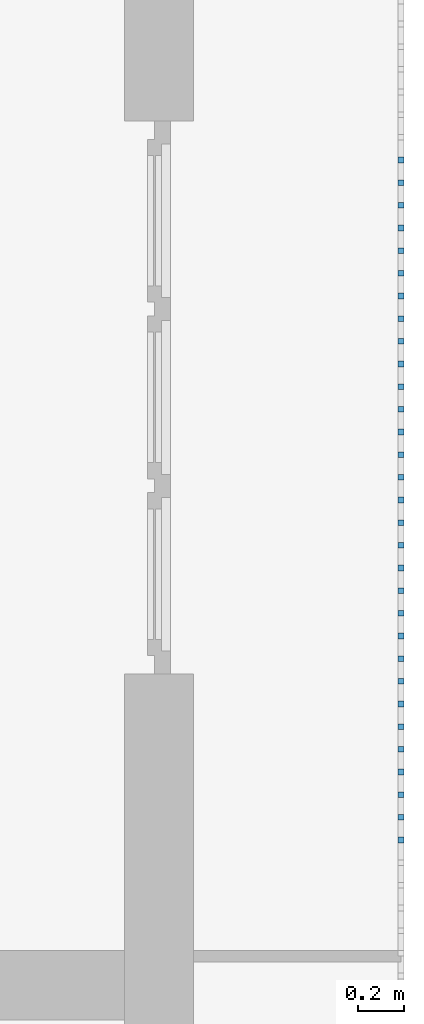
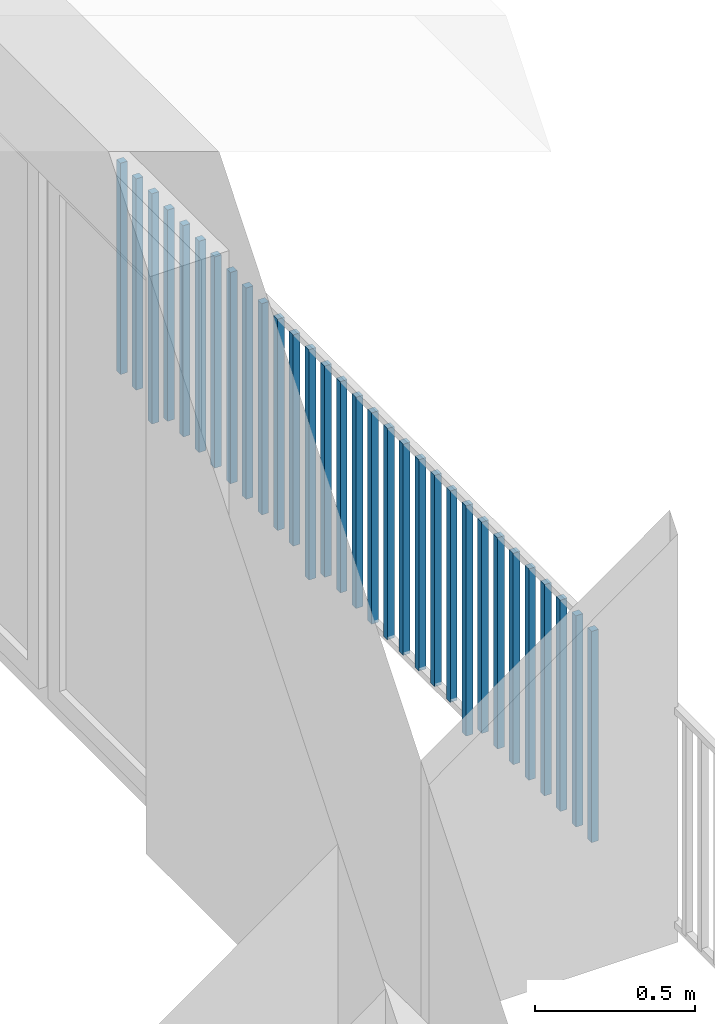
# One storey, part 40 of 48: 31 building element parts, 1 element without a shape of its own.
"""IFC4 building model written with IfcOpenShell, lengths in metres."""

from ifc_helpers import new_model, entity, si_unit, converted_unit, derived_unit, direction, frame, origin_with_axes, place, context, subcontext, project, spatial, polygons, material, type_object, element, aggregate, save


model = new_model("IFC4")

# Units and contexts
model_context = context("Model", 3, precision=1e-05, world=origin_with_axes(), true_north=direction((0.0, 1.0)))
body_context = subcontext(model_context, "Body", "Model", "MODEL_VIEW")
ifc_project = project(units=[si_unit("LENGTHUNIT", "METRE"), si_unit("AREAUNIT", "SQUARE_METRE"), si_unit("VOLUMEUNIT", "CUBIC_METRE"), converted_unit("PLANEANGLEUNIT", "DEGREE", entity("IfcPlaneAngleMeasure", 0.0174532925199), si_unit("PLANEANGLEUNIT", "RADIAN"), dimensions=[0, 0, 0, 0, 0, 0, 0]), converted_unit("TIMEUNIT", "Year", entity("IfcTimeMeasure", 31556926.0), si_unit("TIMEUNIT", "SECOND"), dimensions=[0, 0, 1, 0, 0, 0, 0]), si_unit("MASSUNIT", "GRAM", prefix="KILO"), si_unit("THERMODYNAMICTEMPERATUREUNIT", "DEGREE_CELSIUS"), si_unit("LUMINOUSINTENSITYUNIT", "LUMEN"), si_unit("ENERGYUNIT", "JOULE", prefix="MEGA"), derived_unit("THERMALCONDUCTANCEUNIT", [(si_unit("POWERUNIT", "WATT"), 1), (si_unit("LENGTHUNIT", "METRE"), -1), (si_unit("THERMODYNAMICTEMPERATUREUNIT", "KELVIN"), -1)]), derived_unit("SPECIFICHEATCAPACITYUNIT", [(si_unit("ENERGYUNIT", "JOULE"), 1), (si_unit("MASSUNIT", "GRAM", prefix="KILO"), -1), (si_unit("THERMODYNAMICTEMPERATUREUNIT", "KELVIN"), -1)]), derived_unit("MASSDENSITYUNIT", [(si_unit("MASSUNIT", "GRAM", prefix="KILO"), 1), (si_unit("VOLUMEUNIT", "CUBIC_METRE"), -1)])], contexts=[model_context])

# Site, building, storey
site_placement = place(None, origin_with_axes())
site = spatial("IfcSite", under=ifc_project, at=site_placement, CompositionType="ELEMENT")
building_placement = place(site_placement, origin_with_axes())
building = spatial("IfcBuilding", under=site, at=building_placement, CompositionType="ELEMENT")
storey_placement = place(building_placement, frame((0.0, 0.0, 3.4), z_axis=(0.0, 0.0, 1.0), x_axis=(1.0, 0.0, 0.0)))
storey = spatial("IfcBuildingStorey", under=building, at=storey_placement, Name="1. Geschoss", CompositionType="ELEMENT", Elevation=3.4)

# Railing, building element parts
railing_type = type_object("IfcRailingType", PredefinedType="NOTDEFINED")
railing_placement = place(storey_placement, frame((10.2378006196, 9.82118776896, 0.0), z_axis=(0.0, 0.0, 1.0), x_axis=(1.0, 0.0, 0.0)))
railing = element("IfcRailing", 1, at=railing_placement, inside=storey, type_object=railing_type, PredefinedType="NOTDEFINED")
ifc_material = material()
building_element_part_1_placement = place(railing_placement, origin_with_axes())
building_element_part_1 = element("IfcBuildingElementPart", 2, at=building_element_part_1_placement, material=ifc_material, PredefinedType="NOTDEFINED", context=body_context, shape_type="Tessellation", body=[
    polygons([(0.0125, -7.6575, 0.07), (-0.0125, -7.6575, 0.07), (-0.0125, -7.6575, 0.8775), (0.0125, -7.6575, 0.8775), (0.0125, -7.6825, 0.07), (-0.0125, -7.6825, 0.07), (-0.0125, -7.6825, 0.8775), (0.0125, -7.6825, 0.8775)], [[[1, 2, 3, 4]], [[1, 5, 6, 2]], [[2, 6, 7, 3]], [[4, 3, 7, 8]], [[5, 1, 4, 8]], [[6, 5, 8, 7]]], closed=True),
])
building_element_part_2_placement = place(railing_placement, origin_with_axes())
building_element_part_2 = element("IfcBuildingElementPart", 3, at=building_element_part_2_placement, material=ifc_material, PredefinedType="NOTDEFINED", context=body_context, shape_type="Tessellation", body=[
    polygons([(0.0125, -7.55916666667, 0.07), (-0.0125, -7.55916666667, 0.07), (-0.0125, -7.55916666667, 0.8775), (0.0125, -7.55916666667, 0.8775), (0.0125, -7.58416666667, 0.07), (-0.0125, -7.58416666667, 0.07), (-0.0125, -7.58416666667, 0.8775), (0.0125, -7.58416666667, 0.8775)], [[[1, 2, 3, 4]], [[1, 5, 6, 2]], [[2, 6, 7, 3]], [[4, 3, 7, 8]], [[5, 1, 4, 8]], [[6, 5, 8, 7]]], closed=True),
])
building_element_part_3_placement = place(railing_placement, origin_with_axes())
building_element_part_3 = element("IfcBuildingElementPart", 4, at=building_element_part_3_placement, material=ifc_material, PredefinedType="NOTDEFINED", context=body_context, shape_type="Tessellation", body=[
    polygons([(0.0125, -7.46083333333, 0.07), (-0.0125, -7.46083333333, 0.07), (-0.0125, -7.46083333333, 0.8775), (0.0125, -7.46083333333, 0.8775), (0.0125, -7.48583333333, 0.07), (-0.0125, -7.48583333333, 0.07), (-0.0125, -7.48583333333, 0.8775), (0.0125, -7.48583333333, 0.8775)], [[[1, 2, 3, 4]], [[1, 5, 6, 2]], [[2, 6, 7, 3]], [[4, 3, 7, 8]], [[5, 1, 4, 8]], [[6, 5, 8, 7]]], closed=True),
])
building_element_part_4_placement = place(railing_placement, origin_with_axes())
building_element_part_4 = element("IfcBuildingElementPart", 5, at=building_element_part_4_placement, material=ifc_material, PredefinedType="NOTDEFINED", context=body_context, shape_type="Tessellation", body=[
    polygons([(0.0125, -7.3625, 0.07), (-0.0125, -7.3625, 0.07), (-0.0125, -7.3625, 0.8775), (0.0125, -7.3625, 0.8775), (0.0125, -7.3875, 0.07), (-0.0125, -7.3875, 0.07), (-0.0125, -7.3875, 0.8775), (0.0125, -7.3875, 0.8775)], [[[1, 2, 3, 4]], [[1, 5, 6, 2]], [[2, 6, 7, 3]], [[4, 3, 7, 8]], [[5, 1, 4, 8]], [[6, 5, 8, 7]]], closed=True),
])
building_element_part_5_placement = place(railing_placement, origin_with_axes())
building_element_part_5 = element("IfcBuildingElementPart", 6, at=building_element_part_5_placement, material=ifc_material, PredefinedType="NOTDEFINED", context=body_context, shape_type="Tessellation", body=[
    polygons([(0.0125, -7.26416666667, 0.07), (-0.0125, -7.26416666667, 0.07), (-0.0125, -7.26416666667, 0.8775), (0.0125, -7.26416666667, 0.8775), (0.0125, -7.28916666667, 0.07), (-0.0125, -7.28916666667, 0.07), (-0.0125, -7.28916666667, 0.8775), (0.0125, -7.28916666667, 0.8775)], [[[1, 2, 3, 4]], [[1, 5, 6, 2]], [[2, 6, 7, 3]], [[4, 3, 7, 8]], [[5, 1, 4, 8]], [[6, 5, 8, 7]]], closed=True),
])
building_element_part_6_placement = place(railing_placement, origin_with_axes())
building_element_part_6 = element("IfcBuildingElementPart", 7, at=building_element_part_6_placement, material=ifc_material, PredefinedType="NOTDEFINED", context=body_context, shape_type="Tessellation", body=[
    polygons([(0.0125, -7.16583333333, 0.07), (-0.0125, -7.16583333333, 0.07), (-0.0125, -7.16583333333, 0.8775), (0.0125, -7.16583333333, 0.8775), (0.0125, -7.19083333333, 0.07), (-0.0125, -7.19083333333, 0.07), (-0.0125, -7.19083333333, 0.8775), (0.0125, -7.19083333333, 0.8775)], [[[1, 2, 3, 4]], [[1, 5, 6, 2]], [[2, 6, 7, 3]], [[4, 3, 7, 8]], [[5, 1, 4, 8]], [[6, 5, 8, 7]]], closed=True),
])
building_element_part_7_placement = place(railing_placement, origin_with_axes())
building_element_part_7 = element("IfcBuildingElementPart", 8, at=building_element_part_7_placement, material=ifc_material, PredefinedType="NOTDEFINED", context=body_context, shape_type="Tessellation", body=[
    polygons([(0.0125, -7.0675, 0.07), (-0.0125, -7.0675, 0.07), (-0.0125, -7.0675, 0.8775), (0.0125, -7.0675, 0.8775), (0.0125, -7.0925, 0.07), (-0.0125, -7.0925, 0.07), (-0.0125, -7.0925, 0.8775), (0.0125, -7.0925, 0.8775)], [[[1, 2, 3, 4]], [[1, 5, 6, 2]], [[2, 6, 7, 3]], [[4, 3, 7, 8]], [[5, 1, 4, 8]], [[6, 5, 8, 7]]], closed=True),
])
building_element_part_8_placement = place(railing_placement, origin_with_axes())
building_element_part_8 = element("IfcBuildingElementPart", 9, at=building_element_part_8_placement, material=ifc_material, PredefinedType="NOTDEFINED", context=body_context, shape_type="Tessellation", body=[
    polygons([(0.0125, -6.96916666667, 0.07), (-0.0125, -6.96916666667, 0.07), (-0.0125, -6.96916666667, 0.8775), (0.0125, -6.96916666667, 0.8775), (0.0125, -6.99416666667, 0.07), (-0.0125, -6.99416666667, 0.07), (-0.0125, -6.99416666667, 0.8775), (0.0125, -6.99416666667, 0.8775)], [[[1, 2, 3, 4]], [[1, 5, 6, 2]], [[2, 6, 7, 3]], [[4, 3, 7, 8]], [[5, 1, 4, 8]], [[6, 5, 8, 7]]], closed=True),
])
building_element_part_9_placement = place(railing_placement, origin_with_axes())
building_element_part_9 = element("IfcBuildingElementPart", 10, at=building_element_part_9_placement, material=ifc_material, PredefinedType="NOTDEFINED", context=body_context, shape_type="Tessellation", body=[
    polygons([(0.0125, -6.87083333333, 0.0), (-0.0125, -6.87083333333, 0.0), (-0.0125, -6.87083333333, 0.88), (0.0125, -6.87083333333, 0.88), (0.0125, -6.89583333333, 0.0), (-0.0125, -6.89583333333, 0.0), (-0.0125, -6.89583333333, 0.88), (0.0125, -6.89583333333, 0.88)], [[[1, 2, 3, 4]], [[1, 5, 6, 2]], [[2, 6, 7, 3]], [[4, 3, 7, 8]], [[5, 1, 4, 8]], [[6, 5, 8, 7]]], closed=True),
])
building_element_part_10_placement = place(railing_placement, origin_with_axes())
building_element_part_10 = element("IfcBuildingElementPart", 11, at=building_element_part_10_placement, material=ifc_material, PredefinedType="NOTDEFINED", context=body_context, shape_type="Tessellation", body=[
    polygons([(0.0125, -6.7725, 0.07), (-0.0125, -6.7725, 0.07), (-0.0125, -6.7725, 0.8775), (0.0125, -6.7725, 0.8775), (0.0125, -6.7975, 0.07), (-0.0125, -6.7975, 0.07), (-0.0125, -6.7975, 0.8775), (0.0125, -6.7975, 0.8775)], [[[1, 2, 3, 4]], [[1, 5, 6, 2]], [[2, 6, 7, 3]], [[4, 3, 7, 8]], [[5, 1, 4, 8]], [[6, 5, 8, 7]]], closed=True),
])
building_element_part_11_placement = place(railing_placement, origin_with_axes())
building_element_part_11 = element("IfcBuildingElementPart", 12, at=building_element_part_11_placement, material=ifc_material, PredefinedType="NOTDEFINED", context=body_context, shape_type="Tessellation", body=[
    polygons([(0.0125, -6.67416666667, 0.07), (-0.0125, -6.67416666667, 0.07), (-0.0125, -6.67416666667, 0.8775), (0.0125, -6.67416666667, 0.8775), (0.0125, -6.69916666667, 0.07), (-0.0125, -6.69916666667, 0.07), (-0.0125, -6.69916666667, 0.8775), (0.0125, -6.69916666667, 0.8775)], [[[1, 2, 3, 4]], [[1, 5, 6, 2]], [[2, 6, 7, 3]], [[4, 3, 7, 8]], [[5, 1, 4, 8]], [[6, 5, 8, 7]]], closed=True),
])
building_element_part_12_placement = place(railing_placement, origin_with_axes())
building_element_part_12 = element("IfcBuildingElementPart", 13, at=building_element_part_12_placement, material=ifc_material, PredefinedType="NOTDEFINED", context=body_context, shape_type="Tessellation", body=[
    polygons([(0.0125, -6.57583333333, 0.07), (-0.0125, -6.57583333333, 0.07), (-0.0125, -6.57583333333, 0.8775), (0.0125, -6.57583333333, 0.8775), (0.0125, -6.60083333333, 0.07), (-0.0125, -6.60083333333, 0.07), (-0.0125, -6.60083333333, 0.8775), (0.0125, -6.60083333333, 0.8775)], [[[1, 2, 3, 4]], [[1, 5, 6, 2]], [[2, 6, 7, 3]], [[4, 3, 7, 8]], [[5, 1, 4, 8]], [[6, 5, 8, 7]]], closed=True),
])
building_element_part_13_placement = place(railing_placement, origin_with_axes())
building_element_part_13 = element("IfcBuildingElementPart", 14, at=building_element_part_13_placement, material=ifc_material, PredefinedType="NOTDEFINED", context=body_context, shape_type="Tessellation", body=[
    polygons([(0.0125, -6.4775, 0.07), (-0.0125, -6.4775, 0.07), (-0.0125, -6.4775, 0.8775), (0.0125, -6.4775, 0.8775), (0.0125, -6.5025, 0.07), (-0.0125, -6.5025, 0.07), (-0.0125, -6.5025, 0.8775), (0.0125, -6.5025, 0.8775)], [[[1, 2, 3, 4]], [[1, 5, 6, 2]], [[2, 6, 7, 3]], [[4, 3, 7, 8]], [[5, 1, 4, 8]], [[6, 5, 8, 7]]], closed=True),
])
building_element_part_14_placement = place(railing_placement, origin_with_axes())
building_element_part_14 = element("IfcBuildingElementPart", 15, at=building_element_part_14_placement, material=ifc_material, PredefinedType="NOTDEFINED", context=body_context, shape_type="Tessellation", body=[
    polygons([(0.0125, -6.37916666667, 0.07), (-0.0125, -6.37916666667, 0.07), (-0.0125, -6.37916666667, 0.8775), (0.0125, -6.37916666667, 0.8775), (0.0125, -6.40416666667, 0.07), (-0.0125, -6.40416666667, 0.07), (-0.0125, -6.40416666667, 0.8775), (0.0125, -6.40416666667, 0.8775)], [[[1, 2, 3, 4]], [[1, 5, 6, 2]], [[2, 6, 7, 3]], [[4, 3, 7, 8]], [[5, 1, 4, 8]], [[6, 5, 8, 7]]], closed=True),
])
building_element_part_15_placement = place(railing_placement, origin_with_axes())
building_element_part_15 = element("IfcBuildingElementPart", 16, at=building_element_part_15_placement, material=ifc_material, PredefinedType="NOTDEFINED", context=body_context, shape_type="Tessellation", body=[
    polygons([(0.0125, -6.28083333333, 0.07), (-0.0125, -6.28083333333, 0.07), (-0.0125, -6.28083333333, 0.8775), (0.0125, -6.28083333333, 0.8775), (0.0125, -6.30583333333, 0.07), (-0.0125, -6.30583333333, 0.07), (-0.0125, -6.30583333333, 0.8775), (0.0125, -6.30583333333, 0.8775)], [[[1, 2, 3, 4]], [[1, 5, 6, 2]], [[2, 6, 7, 3]], [[4, 3, 7, 8]], [[5, 1, 4, 8]], [[6, 5, 8, 7]]], closed=True),
])
building_element_part_16_placement = place(railing_placement, origin_with_axes())
building_element_part_16 = element("IfcBuildingElementPart", 17, at=building_element_part_16_placement, material=ifc_material, PredefinedType="NOTDEFINED", context=body_context, shape_type="Tessellation", body=[
    polygons([(0.0125, -6.1825, 0.07), (-0.0125, -6.1825, 0.07), (-0.0125, -6.1825, 0.8775), (0.0125, -6.1825, 0.8775), (0.0125, -6.2075, 0.07), (-0.0125, -6.2075, 0.07), (-0.0125, -6.2075, 0.8775), (0.0125, -6.2075, 0.8775)], [[[1, 2, 3, 4]], [[1, 5, 6, 2]], [[2, 6, 7, 3]], [[4, 3, 7, 8]], [[5, 1, 4, 8]], [[6, 5, 8, 7]]], closed=True),
])
building_element_part_17_placement = place(railing_placement, origin_with_axes())
building_element_part_17 = element("IfcBuildingElementPart", 18, at=building_element_part_17_placement, material=ifc_material, PredefinedType="NOTDEFINED", context=body_context, shape_type="Tessellation", body=[
    polygons([(0.0125, -6.08416666667, 0.07), (-0.0125, -6.08416666667, 0.07), (-0.0125, -6.08416666667, 0.8775), (0.0125, -6.08416666667, 0.8775), (0.0125, -6.10916666667, 0.07), (-0.0125, -6.10916666667, 0.07), (-0.0125, -6.10916666667, 0.8775), (0.0125, -6.10916666667, 0.8775)], [[[1, 2, 3, 4]], [[1, 5, 6, 2]], [[2, 6, 7, 3]], [[4, 3, 7, 8]], [[5, 1, 4, 8]], [[6, 5, 8, 7]]], closed=True),
])
building_element_part_18_placement = place(railing_placement, origin_with_axes())
building_element_part_18 = element("IfcBuildingElementPart", 19, at=building_element_part_18_placement, material=ifc_material, PredefinedType="NOTDEFINED", context=body_context, shape_type="Tessellation", body=[
    polygons([(0.0125, -5.98583333333, 0.07), (-0.0125, -5.98583333333, 0.07), (-0.0125, -5.98583333333, 0.8775), (0.0125, -5.98583333333, 0.8775), (0.0125, -6.01083333333, 0.07), (-0.0125, -6.01083333333, 0.07), (-0.0125, -6.01083333333, 0.8775), (0.0125, -6.01083333333, 0.8775)], [[[1, 2, 3, 4]], [[1, 5, 6, 2]], [[2, 6, 7, 3]], [[4, 3, 7, 8]], [[5, 1, 4, 8]], [[6, 5, 8, 7]]], closed=True),
])
building_element_part_19_placement = place(railing_placement, origin_with_axes())
building_element_part_19 = element("IfcBuildingElementPart", 20, at=building_element_part_19_placement, material=ifc_material, PredefinedType="NOTDEFINED", context=body_context, shape_type="Tessellation", body=[
    polygons([(0.0125, -5.8875, 0.0), (-0.0125, -5.8875, 0.0), (-0.0125, -5.8875, 0.88), (0.0125, -5.8875, 0.88), (0.0125, -5.9125, 0.0), (-0.0125, -5.9125, 0.0), (-0.0125, -5.9125, 0.88), (0.0125, -5.9125, 0.88)], [[[1, 2, 3, 4]], [[1, 5, 6, 2]], [[2, 6, 7, 3]], [[4, 3, 7, 8]], [[5, 1, 4, 8]], [[6, 5, 8, 7]]], closed=True),
])
building_element_part_20_placement = place(railing_placement, origin_with_axes())
building_element_part_20 = element("IfcBuildingElementPart", 21, at=building_element_part_20_placement, material=ifc_material, PredefinedType="NOTDEFINED", context=body_context, shape_type="Tessellation", body=[
    polygons([(0.0125, -5.78916666667, 0.07), (-0.0125, -5.78916666667, 0.07), (-0.0125, -5.78916666667, 0.8775), (0.0125, -5.78916666667, 0.8775), (0.0125, -5.81416666667, 0.07), (-0.0125, -5.81416666667, 0.07), (-0.0125, -5.81416666667, 0.8775), (0.0125, -5.81416666667, 0.8775)], [[[1, 2, 3, 4]], [[1, 5, 6, 2]], [[2, 6, 7, 3]], [[4, 3, 7, 8]], [[5, 1, 4, 8]], [[6, 5, 8, 7]]], closed=True),
])
building_element_part_21_placement = place(railing_placement, origin_with_axes())
building_element_part_21 = element("IfcBuildingElementPart", 22, at=building_element_part_21_placement, material=ifc_material, PredefinedType="NOTDEFINED", context=body_context, shape_type="Tessellation", body=[
    polygons([(0.0125, -5.69083333333, 0.07), (-0.0125, -5.69083333333, 0.07), (-0.0125, -5.69083333333, 0.8775), (0.0125, -5.69083333333, 0.8775), (0.0125, -5.71583333333, 0.07), (-0.0125, -5.71583333333, 0.07), (-0.0125, -5.71583333333, 0.8775), (0.0125, -5.71583333333, 0.8775)], [[[1, 2, 3, 4]], [[1, 5, 6, 2]], [[2, 6, 7, 3]], [[4, 3, 7, 8]], [[5, 1, 4, 8]], [[6, 5, 8, 7]]], closed=True),
])
building_element_part_22_placement = place(railing_placement, origin_with_axes())
building_element_part_22 = element("IfcBuildingElementPart", 23, at=building_element_part_22_placement, material=ifc_material, PredefinedType="NOTDEFINED", context=body_context, shape_type="Tessellation", body=[
    polygons([(0.0125, -5.5925, 0.07), (-0.0125, -5.5925, 0.07), (-0.0125, -5.5925, 0.8775), (0.0125, -5.5925, 0.8775), (0.0125, -5.6175, 0.07), (-0.0125, -5.6175, 0.07), (-0.0125, -5.6175, 0.8775), (0.0125, -5.6175, 0.8775)], [[[1, 2, 3, 4]], [[1, 5, 6, 2]], [[2, 6, 7, 3]], [[4, 3, 7, 8]], [[5, 1, 4, 8]], [[6, 5, 8, 7]]], closed=True),
])
building_element_part_23_placement = place(railing_placement, origin_with_axes())
building_element_part_23 = element("IfcBuildingElementPart", 24, at=building_element_part_23_placement, material=ifc_material, PredefinedType="NOTDEFINED", context=body_context, shape_type="Tessellation", body=[
    polygons([(0.0125, -5.49416666667, 0.07), (-0.0125, -5.49416666667, 0.07), (-0.0125, -5.49416666667, 0.8775), (0.0125, -5.49416666667, 0.8775), (0.0125, -5.51916666667, 0.07), (-0.0125, -5.51916666667, 0.07), (-0.0125, -5.51916666667, 0.8775), (0.0125, -5.51916666667, 0.8775)], [[[1, 2, 3, 4]], [[1, 5, 6, 2]], [[2, 6, 7, 3]], [[4, 3, 7, 8]], [[5, 1, 4, 8]], [[6, 5, 8, 7]]], closed=True),
])
building_element_part_24_placement = place(railing_placement, origin_with_axes())
building_element_part_24 = element("IfcBuildingElementPart", 25, at=building_element_part_24_placement, material=ifc_material, PredefinedType="NOTDEFINED", context=body_context, shape_type="Tessellation", body=[
    polygons([(0.0125, -5.39583333333, 0.07), (-0.0125, -5.39583333333, 0.07), (-0.0125, -5.39583333333, 0.8775), (0.0125, -5.39583333333, 0.8775), (0.0125, -5.42083333333, 0.07), (-0.0125, -5.42083333333, 0.07), (-0.0125, -5.42083333333, 0.8775), (0.0125, -5.42083333333, 0.8775)], [[[1, 2, 3, 4]], [[1, 5, 6, 2]], [[2, 6, 7, 3]], [[4, 3, 7, 8]], [[5, 1, 4, 8]], [[6, 5, 8, 7]]], closed=True),
])
building_element_part_25_placement = place(railing_placement, origin_with_axes())
building_element_part_25 = element("IfcBuildingElementPart", 26, at=building_element_part_25_placement, material=ifc_material, PredefinedType="NOTDEFINED", context=body_context, shape_type="Tessellation", body=[
    polygons([(0.0125, -5.2975, 0.07), (-0.0125, -5.2975, 0.07), (-0.0125, -5.2975, 0.8775), (0.0125, -5.2975, 0.8775), (0.0125, -5.3225, 0.07), (-0.0125, -5.3225, 0.07), (-0.0125, -5.3225, 0.8775), (0.0125, -5.3225, 0.8775)], [[[1, 2, 3, 4]], [[1, 5, 6, 2]], [[2, 6, 7, 3]], [[4, 3, 7, 8]], [[5, 1, 4, 8]], [[6, 5, 8, 7]]], closed=True),
])
building_element_part_26_placement = place(railing_placement, origin_with_axes())
building_element_part_26 = element("IfcBuildingElementPart", 27, at=building_element_part_26_placement, material=ifc_material, PredefinedType="NOTDEFINED", context=body_context, shape_type="Tessellation", body=[
    polygons([(0.0125, -5.19916666667, 0.07), (-0.0125, -5.19916666667, 0.07), (-0.0125, -5.19916666667, 0.8775), (0.0125, -5.19916666667, 0.8775), (0.0125, -5.22416666667, 0.07), (-0.0125, -5.22416666667, 0.07), (-0.0125, -5.22416666667, 0.8775), (0.0125, -5.22416666667, 0.8775)], [[[1, 2, 3, 4]], [[1, 5, 6, 2]], [[2, 6, 7, 3]], [[4, 3, 7, 8]], [[5, 1, 4, 8]], [[6, 5, 8, 7]]], closed=True),
])
building_element_part_27_placement = place(railing_placement, origin_with_axes())
building_element_part_27 = element("IfcBuildingElementPart", 28, at=building_element_part_27_placement, material=ifc_material, PredefinedType="NOTDEFINED", context=body_context, shape_type="Tessellation", body=[
    polygons([(0.0125, -5.10083333333, 0.07), (-0.0125, -5.10083333333, 0.07), (-0.0125, -5.10083333333, 0.8775), (0.0125, -5.10083333333, 0.8775), (0.0125, -5.12583333333, 0.07), (-0.0125, -5.12583333333, 0.07), (-0.0125, -5.12583333333, 0.8775), (0.0125, -5.12583333333, 0.8775)], [[[1, 2, 3, 4]], [[1, 5, 6, 2]], [[2, 6, 7, 3]], [[4, 3, 7, 8]], [[5, 1, 4, 8]], [[6, 5, 8, 7]]], closed=True),
])
building_element_part_28_placement = place(railing_placement, origin_with_axes())
building_element_part_28 = element("IfcBuildingElementPart", 29, at=building_element_part_28_placement, material=ifc_material, PredefinedType="NOTDEFINED", context=body_context, shape_type="Tessellation", body=[
    polygons([(0.0125, -5.0025, 0.07), (-0.0125, -5.0025, 0.07), (-0.0125, -5.0025, 0.8775), (0.0125, -5.0025, 0.8775), (0.0125, -5.0275, 0.07), (-0.0125, -5.0275, 0.07), (-0.0125, -5.0275, 0.8775), (0.0125, -5.0275, 0.8775)], [[[1, 2, 3, 4]], [[1, 5, 6, 2]], [[2, 6, 7, 3]], [[4, 3, 7, 8]], [[5, 1, 4, 8]], [[6, 5, 8, 7]]], closed=True),
])
building_element_part_29_placement = place(railing_placement, origin_with_axes())
building_element_part_29 = element("IfcBuildingElementPart", 30, at=building_element_part_29_placement, material=ifc_material, PredefinedType="NOTDEFINED", context=body_context, shape_type="Tessellation", body=[
    polygons([(0.0125, -4.90416666667, 0.0), (-0.0125, -4.90416666667, 0.0), (-0.0125, -4.90416666667, 0.88), (0.0125, -4.90416666667, 0.88), (0.0125, -4.92916666667, 0.0), (-0.0125, -4.92916666667, 0.0), (-0.0125, -4.92916666667, 0.88), (0.0125, -4.92916666667, 0.88)], [[[1, 2, 3, 4]], [[1, 5, 6, 2]], [[2, 6, 7, 3]], [[4, 3, 7, 8]], [[5, 1, 4, 8]], [[6, 5, 8, 7]]], closed=True),
])
building_element_part_30_placement = place(railing_placement, origin_with_axes())
building_element_part_30 = element("IfcBuildingElementPart", 31, at=building_element_part_30_placement, material=ifc_material, PredefinedType="NOTDEFINED", context=body_context, shape_type="Tessellation", body=[
    polygons([(0.0125, -4.80583333333, 0.07), (-0.0125, -4.80583333333, 0.07), (-0.0125, -4.80583333333, 0.8775), (0.0125, -4.80583333333, 0.8775), (0.0125, -4.83083333333, 0.07), (-0.0125, -4.83083333333, 0.07), (-0.0125, -4.83083333333, 0.8775), (0.0125, -4.83083333333, 0.8775)], [[[1, 2, 3, 4]], [[1, 5, 6, 2]], [[2, 6, 7, 3]], [[4, 3, 7, 8]], [[5, 1, 4, 8]], [[6, 5, 8, 7]]], closed=True),
])
building_element_part_31_placement = place(railing_placement, origin_with_axes())
building_element_part_31 = element("IfcBuildingElementPart", 32, at=building_element_part_31_placement, material=ifc_material, PredefinedType="NOTDEFINED", context=body_context, shape_type="Tessellation", body=[
    polygons([(0.0125, -4.7075, 0.07), (-0.0125, -4.7075, 0.07), (-0.0125, -4.7075, 0.8775), (0.0125, -4.7075, 0.8775), (0.0125, -4.7325, 0.07), (-0.0125, -4.7325, 0.07), (-0.0125, -4.7325, 0.8775), (0.0125, -4.7325, 0.8775)], [[[1, 2, 3, 4]], [[1, 5, 6, 2]], [[2, 6, 7, 3]], [[4, 3, 7, 8]], [[5, 1, 4, 8]], [[6, 5, 8, 7]]], closed=True),
])
aggregate(railing, [building_element_part_1, building_element_part_2, building_element_part_3, building_element_part_4, building_element_part_5, building_element_part_6, building_element_part_7, building_element_part_8, building_element_part_9, building_element_part_10, building_element_part_11, building_element_part_12, building_element_part_13, building_element_part_14, building_element_part_15, building_element_part_16, building_element_part_17, building_element_part_18, building_element_part_19, building_element_part_20, building_element_part_21, building_element_part_22, building_element_part_23, building_element_part_24, building_element_part_25, building_element_part_26, building_element_part_27, building_element_part_28, building_element_part_29, building_element_part_30, building_element_part_31])

save(model, "model.ifc")
